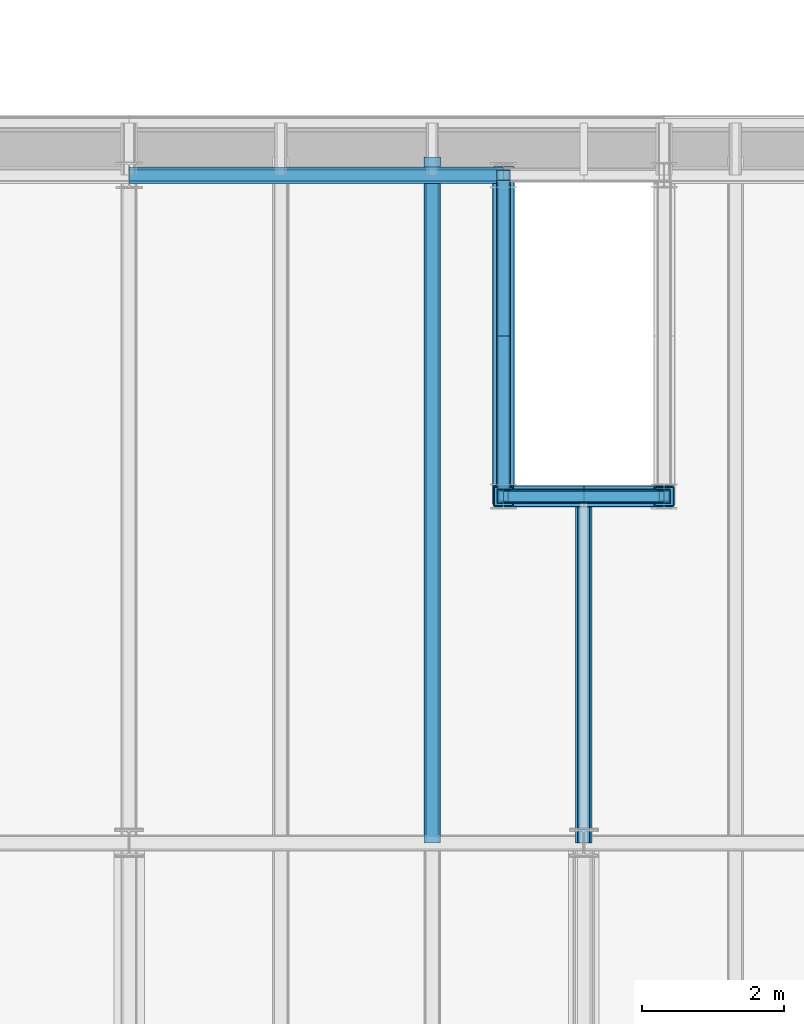
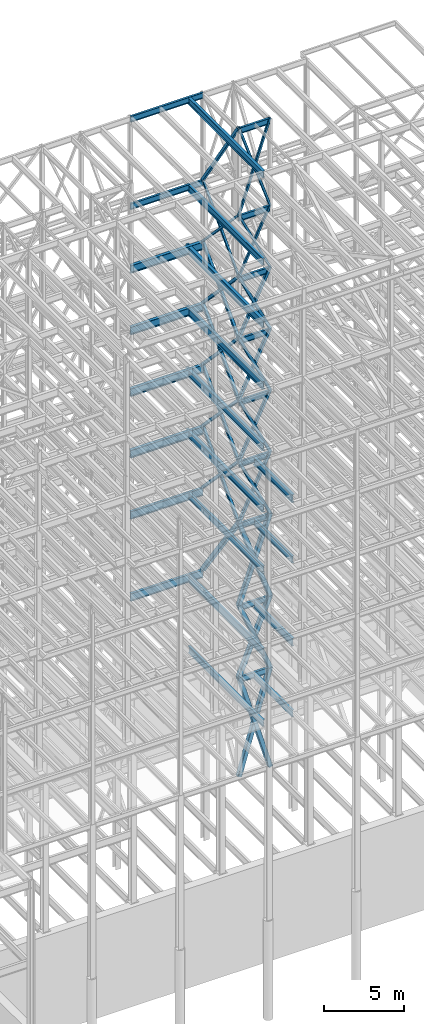
# One storey, part 143 of 150: 60 beams.
"""IFC2X3 building model written with IfcOpenShell, lengths in millimetres."""

from ifc_helpers import new_model, si_unit, frame, origin_with_axes, origin_2d_with_axis, place, context, subcontext, project, spatial, hollow_rectangle, i_section, extrude, material, type_object, element, save


model = new_model("IFC2X3")

# Units and contexts
model_context = context("Model", 3, precision=1e-05, world=origin_with_axes())
body_context = subcontext(model_context, "Body", "Model", "MODEL_VIEW")
ifc_project = project(units=[si_unit("LENGTHUNIT", "METRE", prefix="MILLI"), si_unit("AREAUNIT", "SQUARE_METRE"), si_unit("VOLUMEUNIT", "CUBIC_METRE"), si_unit("MASSUNIT", "GRAM", prefix="KILO"), si_unit("TIMEUNIT", "SECOND"), si_unit("PLANEANGLEUNIT", "RADIAN"), si_unit("SOLIDANGLEUNIT", "STERADIAN"), si_unit("THERMODYNAMICTEMPERATUREUNIT", "DEGREE_CELSIUS"), si_unit("LUMINOUSINTENSITYUNIT", "LUMEN")], contexts=[model_context])

# Site, building, storey
site_placement = place(None, origin_with_axes())
site = spatial("IfcSite", under=ifc_project, at=site_placement, CompositionType="ELEMENT")
building_placement = place(site_placement, origin_with_axes())
building = spatial("IfcBuilding", under=site, at=building_placement, Name="Undefined", CompositionType="ELEMENT")
storey_placement = place(building_placement, origin_with_axes())
storey = spatial("IfcBuildingStorey", under=building, at=storey_placement, Name="Undefined", CompositionType="ELEMENT", Elevation=0.0)

# Beams
ifc_material_1 = material()
beam_type_1 = type_object("IfcBeamType", Name="HSS8X8X3/8", PredefinedType="NOTDEFINED")
beam_1_placement = place(storey_placement, frame((74663.3, 31877.0, 40309.8), z_axis=(0.0, 0.722473115379788, 0.691399014718291), x_axis=(0.0, -0.691399014718292, 0.722473115379787)))
element("IfcBeam", 1, at=beam_1_placement, inside=storey, type_object=beam_type_1, material=ifc_material_1, Name="BEAM", ObjectType="HSS8X8X3/8", context=body_context, shape_type="SweptSolid", body=[
    extrude(hollow_rectangle(XDim=203.2, YDim=203.2, WallThickness=9.525, InnerFilletRadius=9.5249, OuterFilletRadius=19.0499, at=origin_2d_with_axis()), frame((6539.20521164461, 0.0, -3.62998809435833e-13), z_axis=(-1.0, 0.0, 0.0), x_axis=(0.0, -1.0, 0.0)), (0.0, 0.0, 1.0), 6539.20521164461),
])
beam_2_placement = place(storey_placement, frame((74663.3, 27355.8, 40309.8), z_axis=(0.0, -0.722473115379788, 0.691399014718291), x_axis=(0.0, 0.691399014718292, 0.722473115379787)))
element("IfcBeam", 2, at=beam_2_placement, inside=storey, type_object=beam_type_1, material=ifc_material_1, Name="BEAM", ObjectType="HSS8X8X3/8", context=body_context, shape_type="SweptSolid", body=[
    extrude(hollow_rectangle(XDim=203.2, YDim=203.2, WallThickness=9.525, InnerFilletRadius=9.5249, OuterFilletRadius=19.0499, at=origin_2d_with_axis()), frame((6539.20521164461, 0.0, -3.62998809435833e-13), z_axis=(-1.0, 0.0, 0.0), x_axis=(0.0, -1.0, 0.0)), (0.0, 0.0, 1.0), 6539.20521164462),
])
for number, where, z_axis, x_axis, name in (
    (3, (74663.3, 31877.0, 35585.4), (0.0, 0.722473115379788, 0.691399014718291), (0.0, -0.691399014718292, 0.722473115379787), "BEAM"),
    (4, (74663.3, 27355.8, 35585.4), (0.0, -0.722473115379788, 0.691399014718291), (0.0, 0.691399014718292, 0.722473115379787), "BEAM"),
):
    element("IfcBeam", number, at=place(storey_placement, frame(where, z_axis=z_axis, x_axis=x_axis)), inside=storey, type_object=beam_type_1, material=ifc_material_1, Name=name, ObjectType="HSS8X8X3/8", context=body_context, shape_type="SweptSolid", body=[
        extrude(hollow_rectangle(XDim=203.2, YDim=203.2, WallThickness=9.525, InnerFilletRadius=9.5249, OuterFilletRadius=19.0499, at=origin_2d_with_axis()), frame((6539.20521164461, 0.0, -3.62998809435833e-13), z_axis=(-1.0, 0.0, 0.0), x_axis=(0.0, -1.0, 0.0)), (0.0, 0.0, 1.0), 6539.20521164461),
    ])
beam_3_placement = place(storey_placement, frame((74663.3005016625, 27355.8, 40309.7998285212), z_axis=(-0.902052163935922, 0.0, 0.431627030592989), x_axis=(0.431627030592989, 0.0, 0.902052163935922)))
element("IfcBeam", 5, at=beam_3_placement, inside=storey, type_object=beam_type_1, material=ifc_material_1, Name="BEAM", ObjectType="HSS8X8X3/8", context=body_context, shape_type="SweptSolid", body=[
    extrude(hollow_rectangle(XDim=203.2, YDim=203.2, WallThickness=9.525, InnerFilletRadius=9.5249, OuterFilletRadius=19.0499, at=origin_2d_with_axis()), frame((5237.3912468091, 3.63797880709171e-12, 0.0), z_axis=(-1.0, 0.0, 0.0), x_axis=(0.0, -1.0, 0.0)), (0.0, 0.0, 1.0), 5237.39124680913),
])
beam_4_placement = place(storey_placement, frame((76923.9, 27355.8, 35585.4), z_axis=(0.902052163935922, 0.0, 0.431627030592989), x_axis=(-0.431627030592989, 0.0, 0.902052163935922)))
element("IfcBeam", 6, at=beam_4_placement, inside=storey, type_object=beam_type_1, material=ifc_material_1, Name="BEAM", ObjectType="HSS8X8X3/8", context=body_context, shape_type="SweptSolid", body=[
    extrude(hollow_rectangle(XDim=203.2, YDim=203.2, WallThickness=9.525, InnerFilletRadius=9.5249, OuterFilletRadius=19.0499, at=origin_2d_with_axis()), frame((5237.3913086574, 0.0, -7.27595761418343e-12), z_axis=(-1.0, 0.0, 0.0), x_axis=(0.0, -1.0, 0.0)), (0.0, 0.0, 1.0), 5237.3913086574),
])
beam_5_placement = place(storey_placement, frame((76923.8994983375, 27355.8, 40309.7998285212), z_axis=(0.902052163935922, 0.0, 0.431627030592989), x_axis=(-0.431627030592989, 0.0, 0.902052163935922)))
element("IfcBeam", 7, at=beam_5_placement, inside=storey, type_object=beam_type_1, material=ifc_material_1, Name="BEAM", ObjectType="HSS8X8X3/8", context=body_context, shape_type="SweptSolid", body=[
    extrude(hollow_rectangle(XDim=203.2, YDim=203.2, WallThickness=9.525, InnerFilletRadius=9.5249, OuterFilletRadius=19.0499, at=origin_2d_with_axis()), frame((5237.3912468091, 3.63797880709171e-12, 0.0), z_axis=(-1.0, 0.0, 0.0), x_axis=(0.0, -1.0, 0.0)), (0.0, 0.0, 1.0), 5237.39124680914),
])
beam_6_placement = place(storey_placement, frame((74663.3, 27355.8, 35585.4), z_axis=(-0.902052163935922, 0.0, 0.431627030592989), x_axis=(0.431627030592989, 0.0, 0.902052163935922)))
element("IfcBeam", 8, at=beam_6_placement, inside=storey, type_object=beam_type_1, material=ifc_material_1, Name="BEAM", ObjectType="HSS8X8X3/8", context=body_context, shape_type="SweptSolid", body=[
    extrude(hollow_rectangle(XDim=203.2, YDim=203.2, WallThickness=9.525, InnerFilletRadius=9.5249, OuterFilletRadius=19.0499, at=origin_2d_with_axis()), frame((5237.3913086574, 0.0, -7.27595761418343e-12), z_axis=(-1.0, 0.0, 0.0), x_axis=(0.0, -1.0, 0.0)), (0.0, 0.0, 1.0), 5237.3913086574),
])
ifc_material_2 = material(Name="STEEL/A992")
beam_type_2 = type_object("IfcBeamType", Name="W18X35", PredefinedType="NOTDEFINED")
beam_7_placement = place(storey_placement, frame((74663.3, 27355.8, 65687.575), z_axis=(0.0, 0.0, 1.0), x_axis=(1.0, 0.0, 0.0)))
element("IfcBeam", 9, at=beam_7_placement, inside=storey, type_object=beam_type_2, material=ifc_material_2, Name="BEAM", ObjectType="W18X35", context=body_context, shape_type="SweptSolid", body=[
    extrude(i_section(OverallWidth=152.4, OverallDepth=450.85, WebThickness=7.9375, FlangeThickness=10.795, FilletRadius=17.78, at=origin_2d_with_axis()), frame((2260.60000000001, 0.0, 0.0), z_axis=(-1.0, 0.0, 0.0), x_axis=(0.0, -1.0, 0.0)), (0.0, 0.0, 1.0), 2260.60000000001),
])
beam_8_placement = place(storey_placement, frame((69392.8, 31877.0, 65687.575), z_axis=(0.0, 0.0, 1.0), x_axis=(1.0, 0.0, 0.0)))
element("IfcBeam", 10, at=beam_8_placement, inside=storey, type_object=beam_type_2, material=ifc_material_2, Name="BEAM", ObjectType="W18X35", context=body_context, shape_type="SweptSolid", body=[
    extrude(i_section(OverallWidth=152.4, OverallDepth=450.85, WebThickness=7.9375, FlangeThickness=10.795, FilletRadius=17.78, at=origin_2d_with_axis()), frame((5270.5, 0.0, 0.0), z_axis=(-1.0, 0.0, 0.0), x_axis=(0.0, -1.0, 0.0)), (0.0, 0.0, 1.0), 5270.5),
])
beam_9_placement = place(storey_placement, frame((74663.3, 27355.8, 58981.975), z_axis=(0.0, 0.0, 1.0), x_axis=(1.0, 0.0, 0.0)))
element("IfcBeam", 11, at=beam_9_placement, inside=storey, type_object=beam_type_2, material=ifc_material_2, Name="BEAM", ObjectType="W18X35", context=body_context, shape_type="SweptSolid", body=[
    extrude(i_section(OverallWidth=152.4, OverallDepth=450.85, WebThickness=7.9375, FlangeThickness=10.795, FilletRadius=17.78, at=origin_2d_with_axis()), frame((2260.60000000001, 0.0, 0.0), z_axis=(-1.0, 0.0, 0.0), x_axis=(0.0, -1.0, 0.0)), (0.0, 0.0, 1.0), 2260.60000000001),
])
beam_10_placement = place(storey_placement, frame((69392.8, 31877.0, 58981.975), z_axis=(0.0, 0.0, 1.0), x_axis=(1.0, 0.0, 0.0)))
element("IfcBeam", 12, at=beam_10_placement, inside=storey, type_object=beam_type_2, material=ifc_material_2, Name="BEAM", ObjectType="W18X35", context=body_context, shape_type="SweptSolid", body=[
    extrude(i_section(OverallWidth=152.4, OverallDepth=450.85, WebThickness=7.9375, FlangeThickness=10.795, FilletRadius=17.78, at=origin_2d_with_axis()), frame((5270.5, 0.0, 0.0), z_axis=(-1.0, 0.0, 0.0), x_axis=(0.0, -1.0, 0.0)), (0.0, 0.0, 1.0), 5270.5),
])
for number, where, z_axis, x_axis, name in (
    (13, (74663.3, 27355.8, 54257.575), (0.0, 0.0, 1.0), (1.0, 0.0, 0.0), "BEAM"),
    (14, (74663.3, 27355.8, 49533.175), (0.0, 0.0, 1.0), (1.0, 0.0, 0.0), "BEAM"),
    (15, (74663.3, 27355.8, 44808.775), (0.0, 0.0, 1.0), (1.0, 0.0, 0.0), "BEAM"),
    (16, (74663.3, 27355.8, 40084.375), (0.0, 0.0, 1.0), (1.0, 0.0, 0.0), "BEAM"),
    (17, (74663.3, 27355.8, 35359.975), (0.0, 0.0, 1.0), (1.0, 0.0, 0.0), "BEAM"),
    (18, (74663.3, 27355.8, 29060.775), (0.0, 0.0, 1.0), (1.0, 0.0, 0.0), "BEAM"),
    (19, (74663.3, 27355.8, 23548.975), (0.0, 0.0, 1.0), (1.0, 0.0, 0.0), "BEAM"),
):
    element("IfcBeam", number, at=place(storey_placement, frame(where, z_axis=z_axis, x_axis=x_axis)), inside=storey, type_object=beam_type_2, material=ifc_material_2, Name=name, ObjectType="W18X35", context=body_context, shape_type="SweptSolid", body=[
        extrude(i_section(OverallWidth=152.4, OverallDepth=450.85, WebThickness=7.9375, FlangeThickness=10.795, FilletRadius=17.78, at=origin_2d_with_axis()), frame((2260.60000000001, 0.0, 0.0), z_axis=(-1.0, 0.0, 0.0), x_axis=(0.0, -1.0, 0.0)), (0.0, 0.0, 1.0), 2260.60000000001),
    ])
beam_type_3 = type_object("IfcBeamType", Name="HSS8X8X1/4", PredefinedType="NOTDEFINED")
beam_11_placement = place(storey_placement, frame((74663.3, 31877.0, 59207.4), z_axis=(0.0, 0.829139853379412, 0.559041235990662), x_axis=(0.0, -0.559041235990663, 0.829139853379412)))
element("IfcBeam", 20, at=beam_11_placement, inside=storey, type_object=beam_type_3, material=ifc_material_1, Name="BEAM", ObjectType="HSS8X8X1/4", context=body_context, shape_type="SweptSolid", body=[
    extrude(hollow_rectangle(XDim=203.2, YDim=203.2, WallThickness=6.35, InnerFilletRadius=6.3499, OuterFilletRadius=12.6999, at=origin_2d_with_axis()), frame((8087.41743698197, 0.0, 4.48941852414617e-13), z_axis=(-1.0, 0.0, 0.0), x_axis=(0.0, -1.0, 0.0)), (0.0, 0.0, 1.0), 8087.41743698197),
])
for number, where, z_axis, x_axis, name in (
    (21, (74663.3, 31877.0, 49758.6), (0.0, 0.722473115379788, 0.691399014718291), (0.0, -0.691399014718292, 0.722473115379787), "BEAM"),
    (22, (74663.3, 27355.8, 49758.6), (0.0, -0.722473115379788, 0.691399014718291), (0.0, 0.691399014718292, 0.722473115379787), "BEAM"),
):
    element("IfcBeam", number, at=place(storey_placement, frame(where, z_axis=z_axis, x_axis=x_axis)), inside=storey, type_object=beam_type_3, material=ifc_material_1, Name=name, ObjectType="HSS8X8X1/4", context=body_context, shape_type="SweptSolid", body=[
        extrude(hollow_rectangle(XDim=203.2, YDim=203.2, WallThickness=6.35, InnerFilletRadius=6.3499, OuterFilletRadius=12.6999, at=origin_2d_with_axis()), frame((6539.20521164461, 0.0, -3.62998809435833e-13), z_axis=(-1.0, 0.0, 0.0), x_axis=(0.0, -1.0, 0.0)), (0.0, 0.0, 1.0), 6539.20521164461),
    ])
beam_12_placement = place(storey_placement, frame((74663.3, 31877.0, 45034.2), z_axis=(0.0, 0.722473115379788, 0.691399014718291), x_axis=(0.0, -0.691399014718292, 0.722473115379787)))
element("IfcBeam", 23, at=beam_12_placement, inside=storey, type_object=beam_type_3, material=ifc_material_1, Name="BEAM", ObjectType="HSS8X8X1/4", context=body_context, shape_type="SweptSolid", body=[
    extrude(hollow_rectangle(XDim=203.2, YDim=203.2, WallThickness=6.35, InnerFilletRadius=6.3499, OuterFilletRadius=12.6999, at=origin_2d_with_axis()), frame((6539.20535249662, 0.0, -8.00195524869281e-12), z_axis=(-1.0, 0.0, 0.0), x_axis=(0.0, -1.0, 0.0)), (0.0, 0.0, 1.0), 6539.20535249662),
])
beam_13_placement = place(storey_placement, frame((74663.3, 27355.8, 45034.2), z_axis=(0.0, -0.722473115379788, 0.691399014718291), x_axis=(0.0, 0.691399014718292, 0.722473115379787)))
element("IfcBeam", 24, at=beam_13_placement, inside=storey, type_object=beam_type_3, material=ifc_material_1, Name="BEAM", ObjectType="HSS8X8X1/4", context=body_context, shape_type="SweptSolid", body=[
    extrude(hollow_rectangle(XDim=203.2, YDim=203.2, WallThickness=6.35, InnerFilletRadius=6.3499, OuterFilletRadius=12.6999, at=origin_2d_with_axis()), frame((6539.20521164461, 0.0, -3.62998809435833e-13), z_axis=(-1.0, 0.0, 0.0), x_axis=(0.0, -1.0, 0.0)), (0.0, 0.0, 1.0), 6539.20521164461),
])
beam_14_placement = place(storey_placement, frame((74663.3, 27355.8, 49758.6), z_axis=(-0.902052163935922, 0.0, 0.431627030592989), x_axis=(0.431627030592989, 0.0, 0.902052163935922)))
element("IfcBeam", 25, at=beam_14_placement, inside=storey, type_object=beam_type_3, material=ifc_material_1, Name="BEAM", ObjectType="HSS8X8X1/4", context=body_context, shape_type="SweptSolid", body=[
    extrude(hollow_rectangle(XDim=203.2, YDim=203.2, WallThickness=6.35, InnerFilletRadius=6.3499, OuterFilletRadius=12.6999, at=origin_2d_with_axis()), frame((5237.3913086574, 0.0, -7.27595761418343e-12), z_axis=(-1.0, 0.0, 0.0), x_axis=(0.0, -1.0, 0.0)), (0.0, 0.0, 1.0), 5237.3913086574),
])
beam_15_placement = place(storey_placement, frame((76923.8999733046, 27355.8, 45034.199601252), z_axis=(0.902052163935922, 0.0, 0.431627030592989), x_axis=(-0.431627030592989, 0.0, 0.902052163935922)))
element("IfcBeam", 26, at=beam_15_placement, inside=storey, type_object=beam_type_3, material=ifc_material_1, Name="BEAM", ObjectType="HSS8X8X1/4", context=body_context, shape_type="SweptSolid", body=[
    extrude(hollow_rectangle(XDim=203.2, YDim=203.2, WallThickness=6.35, InnerFilletRadius=6.3499, OuterFilletRadius=12.6999, at=origin_2d_with_axis()), frame((5237.39165682641, 3.63797880709171e-12, 0.0), z_axis=(-1.0, 0.0, 0.0), x_axis=(0.0, -1.0, 0.0)), (0.0, 0.0, 1.0), 5237.39165682641),
])
beam_16_placement = place(storey_placement, frame((76923.9, 27355.8, 49758.6), z_axis=(0.902052163935922, 0.0, 0.431627030592989), x_axis=(-0.431627030592989, 0.0, 0.902052163935922)))
element("IfcBeam", 27, at=beam_16_placement, inside=storey, type_object=beam_type_3, material=ifc_material_1, Name="BEAM", ObjectType="HSS8X8X1/4", context=body_context, shape_type="SweptSolid", body=[
    extrude(hollow_rectangle(XDim=203.2, YDim=203.2, WallThickness=6.35, InnerFilletRadius=6.3499, OuterFilletRadius=12.6999, at=origin_2d_with_axis()), frame((5237.3913086574, 0.0, -7.27595761418343e-12), z_axis=(-1.0, 0.0, 0.0), x_axis=(0.0, -1.0, 0.0)), (0.0, 0.0, 1.0), 5237.3913086574),
])
beam_17_placement = place(storey_placement, frame((74663.3000266954, 27355.8, 45034.199601252), z_axis=(-0.902052163935922, 0.0, 0.431627030592989), x_axis=(0.431627030592989, 0.0, 0.902052163935922)))
element("IfcBeam", 28, at=beam_17_placement, inside=storey, type_object=beam_type_3, material=ifc_material_1, Name="BEAM", ObjectType="HSS8X8X1/4", context=body_context, shape_type="SweptSolid", body=[
    extrude(hollow_rectangle(XDim=203.2, YDim=203.2, WallThickness=6.35, InnerFilletRadius=6.3499, OuterFilletRadius=12.6999, at=origin_2d_with_axis()), frame((5237.39165682641, 3.63797880709171e-12, 0.0), z_axis=(-1.0, 0.0, 0.0), x_axis=(0.0, -1.0, 0.0)), (0.0, 0.0, 1.0), 5237.39165682641),
])
beam_type_4 = type_object("IfcBeamType", Name="HSS12X12X5/8", PredefinedType="NOTDEFINED")
beam_18_placement = place(storey_placement, frame((74663.3, 31877.0, 29286.2), z_axis=(0.0, 0.812403320128227, 0.583095914446871), x_axis=(0.0, -0.583095914446872, 0.812403320128227)))
element("IfcBeam", 29, at=beam_18_placement, inside=storey, type_object=beam_type_4, material=ifc_material_1, Name="BEAM", ObjectType="HSS12X12X5/8", context=body_context, shape_type="SweptSolid", body=[
    extrude(hollow_rectangle(XDim=304.8, YDim=304.8, WallThickness=15.875, InnerFilletRadius=15.875, OuterFilletRadius=31.75, at=origin_2d_with_axis()), frame((7753.78424254892, 0.0, 0.0), z_axis=(-1.0, 0.0, 0.0), x_axis=(0.0, -1.0, 0.0)), (0.0, 0.0, 1.0), 7753.78424254892),
])
beam_19_placement = place(storey_placement, frame((74663.3001517776, 27355.8, 29286.1998482629), z_axis=(-0.941225625809532, 0.0, 0.337778509262289), x_axis=(0.337778509262291, 0.0, 0.941225625809532)))
element("IfcBeam", 30, at=beam_19_placement, inside=storey, type_object=beam_type_4, material=ifc_material_1, Name="BEAM", ObjectType="HSS12X12X5/8", context=body_context, shape_type="SweptSolid", body=[
    extrude(hollow_rectangle(XDim=304.8, YDim=304.8, WallThickness=15.875, InnerFilletRadius=15.875, OuterFilletRadius=31.75, at=origin_2d_with_axis()), frame((6692.55065168942, -3.63797880709171e-12, 0.0), z_axis=(-1.0, 0.0, 0.0), x_axis=(0.0, -1.0, 0.0)), (0.0, 0.0, 1.0), 6692.55065168942),
])
beam_20_placement = place(storey_placement, frame((76923.899752884, 27355.8, 23774.3996761532), z_axis=(0.925207030744495, 0.0, 0.379462712609493), x_axis=(-0.379462712609491, 0.0, 0.925207030744496)))
element("IfcBeam", 31, at=beam_20_placement, inside=storey, type_object=beam_type_4, material=ifc_material_1, Name="BEAM", ObjectType="HSS12X12X5/8", context=body_context, shape_type="SweptSolid", body=[
    extrude(hollow_rectangle(XDim=304.8, YDim=304.8, WallThickness=15.875, InnerFilletRadius=15.875, OuterFilletRadius=31.75, at=origin_2d_with_axis()), frame((5957.36972603655, 3.63797880709171e-12, 0.0), z_axis=(-1.0, 0.0, 0.0), x_axis=(0.0, -1.0, 0.0)), (0.0, 0.0, 1.0), 5957.36972603655),
])
beam_21_placement = place(storey_placement, frame((76923.8998482225, 27355.8, 29286.1998482629), z_axis=(0.941225625809532, 0.0, 0.337778509262289), x_axis=(-0.337778509262291, 0.0, 0.941225625809532)))
element("IfcBeam", 32, at=beam_21_placement, inside=storey, type_object=beam_type_4, material=ifc_material_1, Name="BEAM", ObjectType="HSS12X12X5/8", context=body_context, shape_type="SweptSolid", body=[
    extrude(hollow_rectangle(XDim=304.8, YDim=304.8, WallThickness=15.875, InnerFilletRadius=15.875, OuterFilletRadius=31.75, at=origin_2d_with_axis()), frame((6692.55065168942, -3.63797880709171e-12, 0.0), z_axis=(-1.0, 0.0, 0.0), x_axis=(0.0, -1.0, 0.0)), (0.0, 0.0, 1.0), 6692.55065168942),
])
beam_22_placement = place(storey_placement, frame((74663.300247116, 27355.8, 23774.3996761532), z_axis=(-0.925207030744495, 0.0, 0.379462712609493), x_axis=(0.37946271260949, 0.0, 0.925207030744496)))
element("IfcBeam", 33, at=beam_22_placement, inside=storey, type_object=beam_type_4, material=ifc_material_1, Name="BEAM", ObjectType="HSS12X12X5/8", context=body_context, shape_type="SweptSolid", body=[
    extrude(hollow_rectangle(XDim=304.8, YDim=304.8, WallThickness=15.875, InnerFilletRadius=15.875, OuterFilletRadius=31.75, at=origin_2d_with_axis()), frame((5957.36972603655, 3.63797880709171e-12, 0.0), z_axis=(-1.0, 0.0, 0.0), x_axis=(0.0, -1.0, 0.0)), (0.0, 0.0, 1.0), 5957.36972603656),
])
beam_23_placement = place(storey_placement, frame((76923.9, 27355.8, 16154.4), z_axis=(0.95870134592286, 0.0, 0.28441471362378), x_axis=(-0.28441471362378, 0.0, 0.95870134592286)))
element("IfcBeam", 34, at=beam_23_placement, inside=storey, type_object=beam_type_4, material=ifc_material_1, Name="BEAM", ObjectType="HSS12X12X5/8", context=body_context, shape_type="SweptSolid", body=[
    extrude(hollow_rectangle(XDim=304.8, YDim=304.8, WallThickness=15.875, InnerFilletRadius=15.875, OuterFilletRadius=31.75, at=origin_2d_with_axis()), frame((7948.25215755012, 3.63797880709171e-12, 4.41216627541936e-13), z_axis=(-1.0, 0.0, 0.0), x_axis=(0.0, -1.0, 0.0)), (0.0, 0.0, 1.0), 7948.25215755012),
])
beam_24_placement = place(storey_placement, frame((74663.3, 27355.8, 16154.4), z_axis=(-0.958701345922859, 0.0, 0.284414713623782), x_axis=(0.28441471362378, 0.0, 0.95870134592286)))
element("IfcBeam", 35, at=beam_24_placement, inside=storey, type_object=beam_type_4, material=ifc_material_1, Name="BEAM", ObjectType="HSS12X12X5/8", context=body_context, shape_type="SweptSolid", body=[
    extrude(hollow_rectangle(XDim=304.8, YDim=304.8, WallThickness=15.875, InnerFilletRadius=15.875, OuterFilletRadius=31.75, at=origin_2d_with_axis()), frame((7948.25215755012, 3.63797880709171e-12, 4.41216627541936e-13), z_axis=(-1.0, 0.0, 0.0), x_axis=(0.0, -1.0, 0.0)), (0.0, 0.0, 1.0), 7948.25215755011),
])
beam_type_5 = type_object("IfcBeamType", Name="HSS6X6X1/4", PredefinedType="NOTDEFINED")
for number, where, z_axis, x_axis, name in (
    (36, (74663.3, 31877.0, 54483.0), (0.0, 0.722473115379788, 0.691399014718291), (0.0, -0.691399014718292, 0.722473115379787), "BEAM"),
    (37, (74663.3, 27355.8, 54483.0), (0.0, -0.722473115379788, 0.691399014718291), (0.0, 0.691399014718292, 0.722473115379787), "BEAM"),
):
    element("IfcBeam", number, at=place(storey_placement, frame(where, z_axis=z_axis, x_axis=x_axis)), inside=storey, type_object=beam_type_5, material=ifc_material_1, Name=name, ObjectType="HSS6X6X1/4", context=body_context, shape_type="SweptSolid", body=[
        extrude(hollow_rectangle(XDim=152.4, YDim=152.4, WallThickness=6.35, InnerFilletRadius=6.3499, OuterFilletRadius=12.6999, at=origin_2d_with_axis()), frame((6539.20521164461, 0.0, -3.62998809435833e-13), z_axis=(-1.0, 0.0, 0.0), x_axis=(0.0, -1.0, 0.0)), (0.0, 0.0, 1.0), 6539.20521164461),
    ])
beam_25_placement = place(storey_placement, frame((74663.3000266954, 27355.8, 59207.399601252), z_axis=(-0.94760099793907, 0.0, 0.319456333017328), x_axis=(0.319456333017332, 0.0, 0.947600997939069)))
element("IfcBeam", 38, at=beam_25_placement, inside=storey, type_object=beam_type_5, material=ifc_material_1, Name="BEAM", ObjectType="HSS6X6X1/4", context=body_context, shape_type="SweptSolid", body=[
    extrude(hollow_rectangle(XDim=152.4, YDim=152.4, WallThickness=6.35, InnerFilletRadius=6.3499, OuterFilletRadius=12.6999, at=origin_2d_with_axis()), frame((7076.39660752516, 0.0, 0.0), z_axis=(-1.0, 0.0, 0.0), x_axis=(0.0, -1.0, 0.0)), (0.0, 0.0, 1.0), 7076.39660752516),
])
beam_26_placement = place(storey_placement, frame((76923.8994983375, 27355.8, 54482.9998285212), z_axis=(0.902052163935922, 0.0, 0.431627030592989), x_axis=(-0.431627030592989, 0.0, 0.902052163935922)))
element("IfcBeam", 39, at=beam_26_placement, inside=storey, type_object=beam_type_5, material=ifc_material_1, Name="BEAM", ObjectType="HSS6X6X1/4", context=body_context, shape_type="SweptSolid", body=[
    extrude(hollow_rectangle(XDim=152.4, YDim=152.4, WallThickness=6.35, InnerFilletRadius=6.3499, OuterFilletRadius=12.6999, at=origin_2d_with_axis()), frame((5237.3912468091, 3.63797880709171e-12, 0.0), z_axis=(-1.0, 0.0, 0.0), x_axis=(0.0, -1.0, 0.0)), (0.0, 0.0, 1.0), 5237.3912468091),
])
beam_27_placement = place(storey_placement, frame((76923.8999733046, 27355.8, 59207.3996012521), z_axis=(0.94760099793907, 0.0, 0.319456333017328), x_axis=(-0.31945633301733, 0.0, 0.94760099793907)))
element("IfcBeam", 40, at=beam_27_placement, inside=storey, type_object=beam_type_5, material=ifc_material_1, Name="BEAM", ObjectType="HSS6X6X1/4", context=body_context, shape_type="SweptSolid", body=[
    extrude(hollow_rectangle(XDim=152.4, YDim=152.4, WallThickness=6.35, InnerFilletRadius=6.3499, OuterFilletRadius=12.6999, at=origin_2d_with_axis()), frame((7076.39660752516, 0.0, 0.0), z_axis=(-1.0, 0.0, 0.0), x_axis=(0.0, -1.0, 0.0)), (0.0, 0.0, 1.0), 7076.39660752515),
])
beam_28_placement = place(storey_placement, frame((74663.3005016625, 27355.8, 54482.9998285212), z_axis=(-0.902052163935922, 0.0, 0.431627030592989), x_axis=(0.431627030592989, 0.0, 0.902052163935922)))
element("IfcBeam", 41, at=beam_28_placement, inside=storey, type_object=beam_type_5, material=ifc_material_1, Name="BEAM", ObjectType="HSS6X6X1/4", context=body_context, shape_type="SweptSolid", body=[
    extrude(hollow_rectangle(XDim=152.4, YDim=152.4, WallThickness=6.35, InnerFilletRadius=6.3499, OuterFilletRadius=12.6999, at=origin_2d_with_axis()), frame((5237.3912468091, 3.63797880709171e-12, 0.0), z_axis=(-1.0, 0.0, 0.0), x_axis=(0.0, -1.0, 0.0)), (0.0, 0.0, 1.0), 5237.3912468091),
])
beam_type_6 = type_object("IfcBeamType", Name="W24X68", PredefinedType="NOTDEFINED")
beam_29_placement = place(storey_placement, frame((73660.0, 22479.0, 54181.375), z_axis=(0.0, 0.0, 1.0), x_axis=(0.0, 1.0, 0.0)))
element("IfcBeam", 42, at=beam_29_placement, inside=storey, type_object=beam_type_6, material=ifc_material_2, Name="BEAM", ObjectType="W24X68", context=body_context, shape_type="SweptSolid", body=[
    extrude(i_section(OverallWidth=227.838, OverallDepth=603.25, WebThickness=11.1125, FlangeThickness=14.859, FilletRadius=23.2409, at=origin_2d_with_axis()), frame((9652.0, 0.0, 0.0), z_axis=(-1.0, 0.0, 0.0), x_axis=(0.0, -1.0, 0.0)), (0.0, 0.0, 1.0), 9652.0),
])
beam_30_placement = place(storey_placement, frame((69392.8, 31877.0, 54181.375), z_axis=(0.0, 0.0, 1.0), x_axis=(1.0, 0.0, 0.0)))
element("IfcBeam", 43, at=beam_30_placement, inside=storey, type_object=beam_type_6, material=ifc_material_2, Name="BEAM", ObjectType="W24X68", context=body_context, shape_type="SweptSolid", body=[
    extrude(i_section(OverallWidth=227.838, OverallDepth=603.25, WebThickness=11.1125, FlangeThickness=14.859, FilletRadius=23.2409, at=origin_2d_with_axis()), frame((5270.5, 0.0, 0.0), z_axis=(-1.0, 0.0, 0.0), x_axis=(0.0, -1.0, 0.0)), (0.0, 0.0, 1.0), 5270.5),
])
beam_31_placement = place(storey_placement, frame((73660.0, 22479.0, 49456.975), z_axis=(0.0, 0.0, 1.0), x_axis=(0.0, 1.0, 0.0)))
element("IfcBeam", 44, at=beam_31_placement, inside=storey, type_object=beam_type_6, material=ifc_material_2, Name="BEAM", ObjectType="W24X68", context=body_context, shape_type="SweptSolid", body=[
    extrude(i_section(OverallWidth=227.838, OverallDepth=603.25, WebThickness=11.1125, FlangeThickness=14.859, FilletRadius=23.2409, at=origin_2d_with_axis()), frame((9652.0, 0.0, 0.0), z_axis=(-1.0, 0.0, 0.0), x_axis=(0.0, -1.0, 0.0)), (0.0, 0.0, 1.0), 9652.0),
])
beam_32_placement = place(storey_placement, frame((69392.8, 31877.0, 49456.975), z_axis=(0.0, 0.0, 1.0), x_axis=(1.0, 0.0, 0.0)))
element("IfcBeam", 45, at=beam_32_placement, inside=storey, type_object=beam_type_6, material=ifc_material_2, Name="BEAM", ObjectType="W24X68", context=body_context, shape_type="SweptSolid", body=[
    extrude(i_section(OverallWidth=227.838, OverallDepth=603.25, WebThickness=11.1125, FlangeThickness=14.859, FilletRadius=23.2409, at=origin_2d_with_axis()), frame((5270.5, 0.0, 0.0), z_axis=(-1.0, 0.0, 0.0), x_axis=(0.0, -1.0, 0.0)), (0.0, 0.0, 1.0), 5270.5),
])
beam_33_placement = place(storey_placement, frame((73660.0, 22479.0, 44732.575), z_axis=(0.0, 0.0, 1.0), x_axis=(0.0, 1.0, 0.0)))
element("IfcBeam", 46, at=beam_33_placement, inside=storey, type_object=beam_type_6, material=ifc_material_2, Name="BEAM", ObjectType="W24X68", context=body_context, shape_type="SweptSolid", body=[
    extrude(i_section(OverallWidth=227.838, OverallDepth=603.25, WebThickness=11.1125, FlangeThickness=14.859, FilletRadius=23.2409, at=origin_2d_with_axis()), frame((9652.0, 0.0, 0.0), z_axis=(-1.0, 0.0, 0.0), x_axis=(0.0, -1.0, 0.0)), (0.0, 0.0, 1.0), 9652.0),
])
beam_34_placement = place(storey_placement, frame((69392.8, 31877.0, 44732.575), z_axis=(0.0, 0.0, 1.0), x_axis=(1.0, 0.0, 0.0)))
element("IfcBeam", 47, at=beam_34_placement, inside=storey, type_object=beam_type_6, material=ifc_material_2, Name="BEAM", ObjectType="W24X68", context=body_context, shape_type="SweptSolid", body=[
    extrude(i_section(OverallWidth=227.838, OverallDepth=603.25, WebThickness=11.1125, FlangeThickness=14.859, FilletRadius=23.2409, at=origin_2d_with_axis()), frame((5270.5, 0.0, 0.0), z_axis=(-1.0, 0.0, 0.0), x_axis=(0.0, -1.0, 0.0)), (0.0, 0.0, 1.0), 5270.5),
])
beam_35_placement = place(storey_placement, frame((75793.6, 22479.0, 40008.175), z_axis=(0.0, 0.0, 1.0), x_axis=(0.0, 1.0, 0.0)))
element("IfcBeam", 48, at=beam_35_placement, inside=storey, type_object=beam_type_6, material=ifc_material_2, Name="BEAM", ObjectType="W24X68", context=body_context, shape_type="SweptSolid", body=[
    extrude(i_section(OverallWidth=227.838, OverallDepth=603.25, WebThickness=11.1125, FlangeThickness=14.859, FilletRadius=23.2409, at=origin_2d_with_axis()), frame((4876.8, 0.0, 0.0), z_axis=(-1.0, 0.0, 0.0), x_axis=(0.0, -1.0, 0.0)), (0.0, 0.0, 1.0), 4876.8),
])
beam_36_placement = place(storey_placement, frame((73660.0, 22479.0, 40008.175), z_axis=(0.0, 0.0, 1.0), x_axis=(0.0, 1.0, 0.0)))
element("IfcBeam", 49, at=beam_36_placement, inside=storey, type_object=beam_type_6, material=ifc_material_2, Name="BEAM", ObjectType="W24X68", context=body_context, shape_type="SweptSolid", body=[
    extrude(i_section(OverallWidth=227.838, OverallDepth=603.25, WebThickness=11.1125, FlangeThickness=14.859, FilletRadius=23.2409, at=origin_2d_with_axis()), frame((9652.0, 0.0, 0.0), z_axis=(-1.0, 0.0, 0.0), x_axis=(0.0, -1.0, 0.0)), (0.0, 0.0, 1.0), 9652.0),
])
beam_37_placement = place(storey_placement, frame((69392.8, 31877.0, 40008.175), z_axis=(0.0, 0.0, 1.0), x_axis=(1.0, 0.0, 0.0)))
element("IfcBeam", 50, at=beam_37_placement, inside=storey, type_object=beam_type_6, material=ifc_material_2, Name="BEAM", ObjectType="W24X68", context=body_context, shape_type="SweptSolid", body=[
    extrude(i_section(OverallWidth=227.838, OverallDepth=603.25, WebThickness=11.1125, FlangeThickness=14.859, FilletRadius=23.2409, at=origin_2d_with_axis()), frame((5270.5, 0.0, 0.0), z_axis=(-1.0, 0.0, 0.0), x_axis=(0.0, -1.0, 0.0)), (0.0, 0.0, 1.0), 5270.5),
])
beam_type_7 = type_object("IfcBeamType", Name="W21X55", PredefinedType="NOTDEFINED")
for number, where, z_axis, x_axis, name in (
    (51, (73660.0, 22479.0, 65649.475), (0.0, 0.0, 1.0), (0.0, 1.0, 0.0), "BEAM"),
    (52, (73660.0, 22479.0, 58943.875), (0.0, 0.0, 1.0), (0.0, 1.0, 0.0), "BEAM"),
):
    element("IfcBeam", number, at=place(storey_placement, frame(where, z_axis=z_axis, x_axis=x_axis)), inside=storey, type_object=beam_type_7, material=ifc_material_2, Name=name, ObjectType="W21X55", context=body_context, shape_type="SweptSolid", body=[
        extrude(i_section(OverallWidth=208.788, OverallDepth=527.05, WebThickness=9.5, FlangeThickness=13.2588, FilletRadius=16.8624, at=origin_2d_with_axis()), frame((9398.0, 0.0, 0.0), z_axis=(-1.0, 0.0, 0.0), x_axis=(0.0, -1.0, 0.0)), (0.0, 0.0, 1.0), 9398.0),
    ])
beam_type_8 = type_object("IfcBeamType", Name="W24X55", PredefinedType="NOTDEFINED")
beam_38_placement = place(storey_placement, frame((75793.6, 22479.0, 28986.1625), z_axis=(0.0, 0.0, 1.0), x_axis=(0.0, 1.0, 0.0)))
element("IfcBeam", 53, at=beam_38_placement, inside=storey, type_object=beam_type_8, material=ifc_material_2, Name="BEAM", ObjectType="W24X55", context=body_context, shape_type="SweptSolid", body=[
    extrude(i_section(OverallWidth=178.054, OverallDepth=600.075, WebThickness=9.5249, FlangeThickness=12.827, FilletRadius=23.6854, at=origin_2d_with_axis()), frame((4876.8, 0.0, 0.0), z_axis=(-1.0, 0.0, 0.0), x_axis=(0.0, -1.0, 0.0)), (0.0, 0.0, 1.0), 4876.8),
])
beam_39_placement = place(storey_placement, frame((69392.8, 31877.0, 28986.1625), z_axis=(0.0, 0.0, 1.0), x_axis=(1.0, 0.0, 0.0)))
element("IfcBeam", 54, at=beam_39_placement, inside=storey, type_object=beam_type_8, material=ifc_material_2, Name="BEAM", ObjectType="W24X55", context=body_context, shape_type="SweptSolid", body=[
    extrude(i_section(OverallWidth=178.054, OverallDepth=600.075, WebThickness=9.5249, FlangeThickness=12.827, FilletRadius=23.6854, at=origin_2d_with_axis()), frame((5270.5, 0.0, 0.0), z_axis=(-1.0, 0.0, 0.0), x_axis=(0.0, -1.0, 0.0)), (0.0, 0.0, 1.0), 5270.5),
])
beam_40_placement = place(storey_placement, frame((73660.0, 22479.0, 28986.1625), z_axis=(0.0, 0.0, 1.0), x_axis=(0.0, 1.0, 0.0)))
element("IfcBeam", 55, at=beam_40_placement, inside=storey, type_object=beam_type_8, material=ifc_material_2, Name="BEAM", ObjectType="W24X55", context=body_context, shape_type="SweptSolid", body=[
    extrude(i_section(OverallWidth=178.054, OverallDepth=600.075, WebThickness=9.5249, FlangeThickness=12.827, FilletRadius=23.6854, at=origin_2d_with_axis()), frame((9398.0, 0.0, 0.0), z_axis=(-1.0, 0.0, 0.0), x_axis=(0.0, -1.0, 0.0)), (0.0, 0.0, 1.0), 9398.00000000001),
])
beam_type_9 = type_object("IfcBeamType", Name="W21X44", PredefinedType="NOTDEFINED")
beam_41_placement = place(storey_placement, frame((75793.6, 22479.0, 35323.4625), z_axis=(0.0, 0.0, 1.0), x_axis=(0.0, 1.0, 0.0)))
element("IfcBeam", 56, at=beam_41_placement, inside=storey, type_object=beam_type_9, material=ifc_material_2, Name="BEAM", ObjectType="W21X44", context=body_context, shape_type="SweptSolid", body=[
    extrude(i_section(OverallWidth=165.1, OverallDepth=523.875, WebThickness=9.5249, FlangeThickness=11.43, FilletRadius=17.145, at=origin_2d_with_axis()), frame((4876.8, 0.0, 0.0), z_axis=(-1.0, 0.0, 0.0), x_axis=(0.0, -1.0, 0.0)), (0.0, 0.0, 1.0), 4876.8),
])
beam_42_placement = place(storey_placement, frame((73659.99935992, 22479.0, 35323.4625), z_axis=(0.0, 0.0, 1.0), x_axis=(0.0, 1.0, 0.0)))
element("IfcBeam", 57, at=beam_42_placement, inside=storey, type_object=beam_type_9, material=ifc_material_2, Name="BEAM", ObjectType="W21X44", context=body_context, shape_type="SweptSolid", body=[
    extrude(i_section(OverallWidth=165.1, OverallDepth=523.875, WebThickness=9.5249, FlangeThickness=11.43, FilletRadius=17.145, at=origin_2d_with_axis()), frame((9398.0, 0.0, 0.0), z_axis=(-1.0, 0.0, 0.0), x_axis=(0.0, -1.0, 0.0)), (0.0, 0.0, 1.0), 9398.00000000001),
])
beam_43_placement = place(storey_placement, frame((75793.6, 22479.0, 23512.4625), z_axis=(0.0, 0.0, 1.0), x_axis=(0.0, 1.0, 0.0)))
element("IfcBeam", 58, at=beam_43_placement, inside=storey, type_object=beam_type_9, material=ifc_material_2, Name="BEAM", ObjectType="W21X44", context=body_context, shape_type="SweptSolid", body=[
    extrude(i_section(OverallWidth=165.1, OverallDepth=523.875, WebThickness=9.5249, FlangeThickness=11.43, FilletRadius=17.145, at=origin_2d_with_axis()), frame((4876.8, 0.0, 0.0), z_axis=(-1.0, 0.0, 0.0), x_axis=(0.0, -1.0, 0.0)), (0.0, 0.0, 1.0), 4876.8),
])
beam_44_placement = place(storey_placement, frame((73660.0, 22479.0, 23512.4625), z_axis=(0.0, 0.0, 1.0), x_axis=(0.0, 1.0, 0.0)))
element("IfcBeam", 59, at=beam_44_placement, inside=storey, type_object=beam_type_9, material=ifc_material_2, Name="BEAM", ObjectType="W21X44", context=body_context, shape_type="SweptSolid", body=[
    extrude(i_section(OverallWidth=165.1, OverallDepth=523.875, WebThickness=9.5249, FlangeThickness=11.43, FilletRadius=17.145, at=origin_2d_with_axis()), frame((9398.0, 0.0, 0.0), z_axis=(-1.0, 0.0, 0.0), x_axis=(0.0, -1.0, 0.0)), (0.0, 0.0, 1.0), 9398.00000000001),
])
beam_type_10 = type_object("IfcBeamType", Name="W24X62", PredefinedType="NOTDEFINED")
beam_45_placement = place(storey_placement, frame((69392.8, 31877.0, 35283.775), z_axis=(0.0, 0.0, 1.0), x_axis=(1.0, 0.0, 0.0)))
element("IfcBeam", 60, at=beam_45_placement, inside=storey, type_object=beam_type_10, material=ifc_material_2, Name="BEAM", ObjectType="W24X62", context=body_context, shape_type="SweptSolid", body=[
    extrude(i_section(OverallWidth=177.8, OverallDepth=603.25, WebThickness=11.1125, FlangeThickness=14.986, FilletRadius=23.114, at=origin_2d_with_axis()), frame((5270.5, 0.0, 0.0), z_axis=(-1.0, 0.0, 0.0), x_axis=(0.0, -1.0, 0.0)), (0.0, 0.0, 1.0), 5270.5),
])

save(model, "model.ifc")
